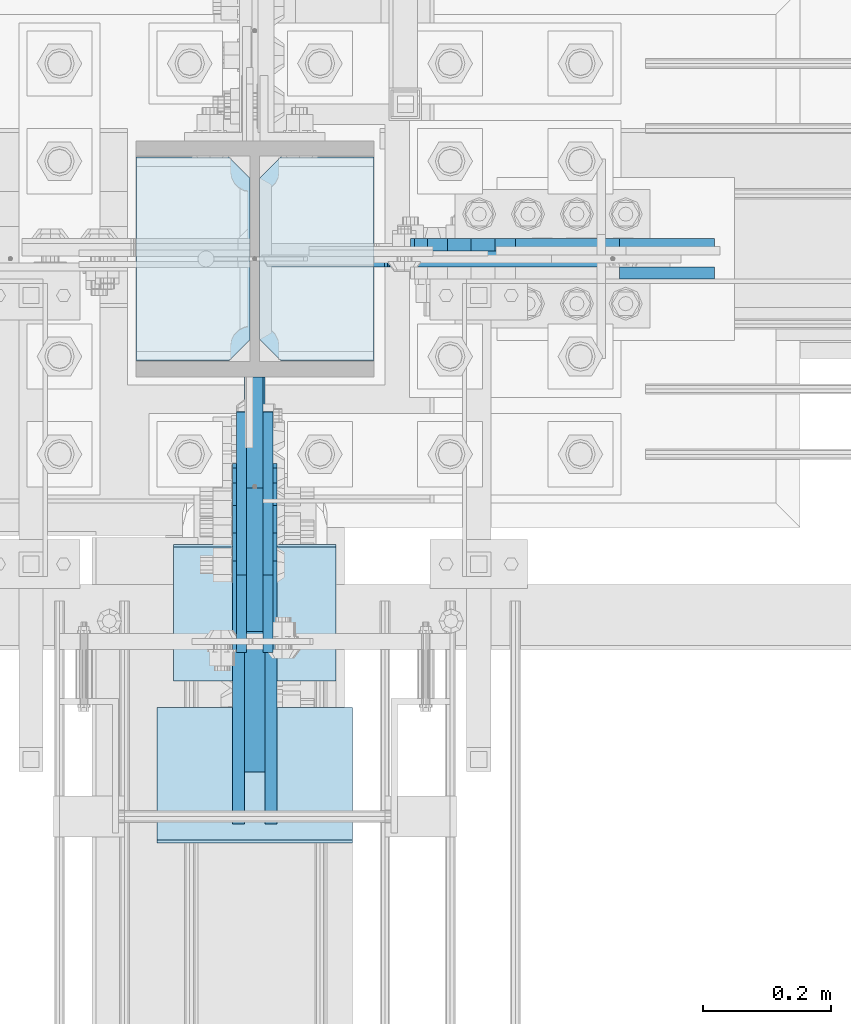
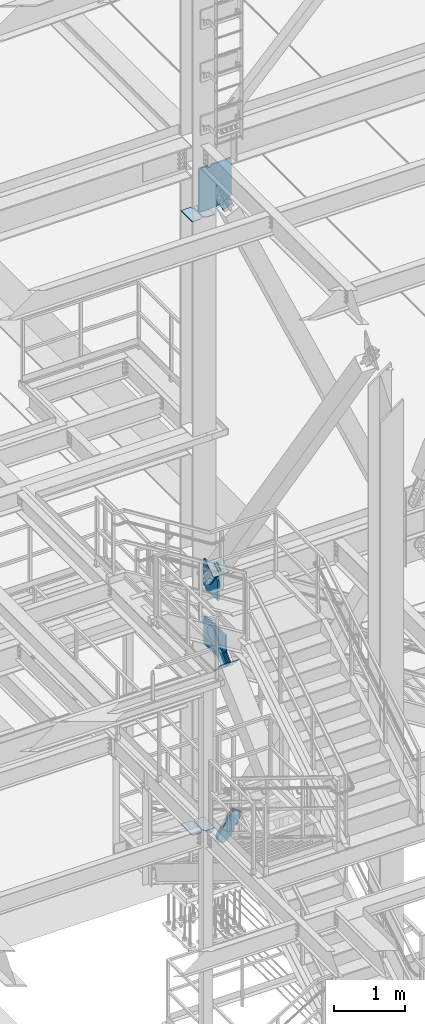
# One storey, part 3150 of 3843: 16 plates, 10 elements without a shape of their own.
"""IFC2X3 building model written with IfcOpenShell, lengths in millimetres."""

import ifcopenshell
import ifcopenshell.guid

model = None  # the IFC model being written
_history = None  # IfcOwnerHistory: only IFC2X3 demands one
_inside = {}  # id of a spatial element -> (the spatial element, [elements in it])
_under = {}  # id of a project, library or spatial element -> (it, [spatial elements below it])
_declared = {}  # id of a project -> (the project, [libraries it declares])
_typed = {}  # id of a type object -> (the type object, [elements of that type])
_made_of = {}  # id of a material, layer set ... -> (it, [elements and type objects made of it])


def new_model(schema):
    """Start an empty IFC model of exactly this schema.

    Asked for "IFC4X3", IfcOpenShell would pick the latest addendum, in which some entities
    have other attributes; the version numbers below select the first issue.
    IFC2X3 requires an IfcOwnerHistory on every rooted entity: one is made here for all.
    """
    global model, _history
    if schema == "IFC4X3":
        model = ifcopenshell.file(schema_version=(4, 3, 0, 0))
    else:
        model = ifcopenshell.file(schema=schema)
    _inside.clear()
    _under.clear()
    _declared.clear()
    _typed.clear()
    _made_of.clear()
    _history = None
    if model.schema == "IFC2X3":
        org = make("IfcOrganization", Name="unknown")
        user = make(
            "IfcPersonAndOrganization",
            ThePerson=make("IfcPerson", FamilyName="unknown"),
            TheOrganization=org,
        )
        app = make(
            "IfcApplication",
            ApplicationDeveloper=org,
            Version="unknown",
            ApplicationFullName="unknown",
            ApplicationIdentifier="unknown",
        )
        _history = make(
            "IfcOwnerHistory",
            OwningUser=user,
            OwningApplication=app,
            ChangeAction="ADDED",
            CreationDate=0,
        )
    return model


def make(cls, **values):
    """One entity of the class cls with the attributes given. An attribute that is None is left unset."""
    return model.create_entity(
        cls, **{name: value for name, value in values.items() if value is not None}
    )


def rooted(cls, **values):
    """An entity with a GlobalId (a new one), such as an element, a storey or a relation."""
    return make(cls, GlobalId=ifcopenshell.guid.new(), OwnerHistory=_history, **values)


def si_unit(unit_type, name, prefix=None):
    """IfcSIUnit, for example si_unit("LENGTHUNIT", "METRE", prefix="MILLI")."""
    return make("IfcSIUnit", UnitType=unit_type, Prefix=prefix, Name=name)


def assignment(units):
    """IfcUnitAssignment: the units of a project."""
    return None if units is None else make("IfcUnitAssignment", Units=units)


def point(xyz):
    """IfcCartesianPoint."""
    return None if xyz is None else make("IfcCartesianPoint", Coordinates=xyz)


def direction(xyz):
    """IfcDirection."""
    return None if xyz is None else make("IfcDirection", DirectionRatios=xyz)


def frame(location, z_axis=None, x_axis=None):
    """IfcAxis2Placement3D, a coordinate frame: its origin and axes. An axis left out is left unset."""
    return make(
        "IfcAxis2Placement3D",
        Location=point(location),
        Axis=direction(z_axis),
        RefDirection=direction(x_axis),
    )


def origin_with_axes():
    """The frame at (0, 0, 0) with the z axis (0, 0, 1) and the x axis (1, 0, 0) written out."""
    return frame((0.0, 0.0, 0.0), z_axis=(0.0, 0.0, 1.0), x_axis=(1.0, 0.0, 0.0))


def place(relative_to, where):
    """IfcLocalPlacement: puts the frame where relative to a parent placement (None: the world)."""
    return make(
        "IfcLocalPlacement", PlacementRelTo=relative_to, RelativePlacement=where
    )


def context(
    kind, dimensions, precision=None, world=None, true_north=None, identifier=None
):
    """IfcGeometricRepresentationContext, for example the 3D "Model" context."""
    return make(
        "IfcGeometricRepresentationContext",
        ContextIdentifier=identifier,
        ContextType=kind,
        CoordinateSpaceDimension=dimensions,
        Precision=precision,
        WorldCoordinateSystem=world,
        TrueNorth=true_north,
    )


def subcontext(parent, identifier, kind, view, scale=None):
    """IfcGeometricRepresentationSubContext, for example "Body" below "Model"."""
    return make(
        "IfcGeometricRepresentationSubContext",
        ContextIdentifier=identifier,
        ContextType=kind,
        ParentContext=parent,
        TargetScale=scale,
        TargetView=view,
    )


def project(units=None, contexts=None):
    """IfcProject with its units and contexts."""
    return rooted(
        "IfcProject",
        Name="project",
        RepresentationContexts=contexts,
        UnitsInContext=assignment(units),
    )


def spatial(cls, under=None, at=None, **own):
    """A site, building, storey or space (cls), placed at a placement, below another one or the project."""
    s = rooted(cls, ObjectPlacement=at, **own)
    if under is not None:
        _under.setdefault(under.id(), (under, []))[1].append(s)
    return s


def faces_of(points, faces, orient=None, outer=None):
    """IfcFace entities. A face is a list of loops; a loop is a list of indices into points, from 0.

    orient and outer hold one flag for each loop. By default every Orientation is true, the
    first loop of a face is its IfcFaceOuterBound and the others are IfcFaceBound.
    """
    made = []
    for i, loops in enumerate(faces):
        bounds = []
        for j, loop in enumerate(loops):
            is_outer = j == 0 if outer is None else outer[i][j]
            bounds.append(
                make(
                    "IfcFaceOuterBound" if is_outer else "IfcFaceBound",
                    Bound=make("IfcPolyLoop", Polygon=[points[k] for k in loop]),
                    Orientation=True if orient is None else orient[i][j],
                )
            )
        made.append(make("IfcFace", Bounds=bounds))
    return made


def faceted_brep(points, faces, orient=None, outer=None, voids=None):
    """IfcFacetedBrep: a solid bounded by flat faces; with voids (closed shells), ...WithVoids."""
    shared = [point(p) for p in points]
    hull = make("IfcClosedShell", CfsFaces=faces_of(shared, faces, orient, outer))
    if voids is None:
        return make("IfcFacetedBrep", Outer=hull)
    return make(
        "IfcFacetedBrepWithVoids",
        Outer=hull,
        Voids=[
            make(cls, CfsFaces=faces_of(shared, fs, o, b)) for cls, fs, o, b in voids
        ],
    )


def shape(context_of_items, identifier, shape_type, items):
    """IfcShapeRepresentation: the items that make up one representation, for example the "Body"."""
    return make(
        "IfcShapeRepresentation",
        ContextOfItems=context_of_items,
        RepresentationIdentifier=identifier,
        RepresentationType=shape_type,
        Items=items,
    )


def material(Name=None, Category=None):
    """IfcMaterial."""
    return make("IfcMaterial", Name=Name, Category=Category)


def made_of(thing, what):
    """Note that an element or type object is made of a material, layer set ...; save() writes the relation."""
    if what is not None:
        _made_of.setdefault(what.id(), (what, []))[1].append(thing)
    return thing


def type_object(cls, material=None, **own):
    """A type object (cls), such as IfcWallType, which elements share."""
    return made_of(rooted(cls, **own), material)


def element(
    cls,
    number,
    at=None,
    inside=None,
    cuts=None,
    type_object=None,
    material=None,
    context=None,
    identifier="Body",
    shape_type=None,
    held_by="IfcProductDefinitionShape",
    body=None,
    shapes=None,
    **own,
):
    """One element of the class cls, such as IfcWall. Its Tag is "e" and its number.

    at: its placement. inside: the storey or other place that contains it. cuts: it is an
    opening in that element (IfcRelVoidsElement). A single representation is given by context,
    identifier, shape_type and body (its items); several are given by shapes. held_by: the class
    of the entity that holds the representations. save() writes the other relations.
    """
    e = rooted(cls, Tag="e%d" % number, ObjectPlacement=at, **own)
    if body is not None:
        shapes = [shape(context, identifier, shape_type, body)]
    if shapes is not None:
        e.Representation = make(held_by, Representations=shapes)
    if inside is not None:
        _inside.setdefault(inside.id(), (inside, []))[1].append(e)
    if cuts is not None:
        rooted(
            "IfcRelVoidsElement", RelatingBuildingElement=cuts, RelatedOpeningElement=e
        )
    if type_object is not None:
        _typed.setdefault(type_object.id(), (type_object, []))[1].append(e)
    return made_of(e, material)


def aggregate(whole, parts):
    """IfcRelAggregates: a whole, such as a stair, and the parts it consists of."""
    return rooted("IfcRelAggregates", RelatingObject=whole, RelatedObjects=parts)


def save(model, path):
    """Write the relations noted so far, then the file.

    IfcRelAggregates (storeys below a building ...), IfcRelContainedInSpatialStructure (elements
    in a storey), IfcRelDefinesByType, IfcRelAssociatesMaterial and IfcRelDeclares: one each for
    every whole, place, type object, material and project.
    """
    for whole, parts in _under.values():
        aggregate(whole, parts)
    for where, things in _inside.values():
        rooted(
            "IfcRelContainedInSpatialStructure",
            RelatedElements=things,
            RelatingStructure=where,
        )
    for kind, things in _typed.values():
        rooted("IfcRelDefinesByType", RelatedObjects=things, RelatingType=kind)
    for what, things in _made_of.values():
        rooted("IfcRelAssociatesMaterial", RelatedObjects=things, RelatingMaterial=what)
    for by, libraries in _declared.values():
        rooted("IfcRelDeclares", RelatingContext=by, RelatedDefinitions=libraries)
    model.write(path)


model = new_model("IFC2X3")

# Units and contexts
model_context = context("Model", 3, precision=1e-05, world=origin_with_axes())
body_context = subcontext(model_context, "Body", "Model", "MODEL_VIEW")
ifc_project = project(units=[si_unit("LENGTHUNIT", "METRE", prefix="MILLI"), si_unit("AREAUNIT", "SQUARE_METRE"), si_unit("VOLUMEUNIT", "CUBIC_METRE"), si_unit("MASSUNIT", "GRAM", prefix="KILO"), si_unit("TIMEUNIT", "SECOND"), si_unit("PLANEANGLEUNIT", "RADIAN"), si_unit("SOLIDANGLEUNIT", "STERADIAN"), si_unit("THERMODYNAMICTEMPERATUREUNIT", "DEGREE_CELSIUS"), si_unit("LUMINOUSINTENSITYUNIT", "LUMEN")], contexts=[model_context])

# Site, building, storey
site_placement = place(None, origin_with_axes())
site = spatial("IfcSite", under=ifc_project, at=site_placement, CompositionType="ELEMENT")
building_placement = place(site_placement, origin_with_axes())
building = spatial("IfcBuilding", under=site, at=building_placement, Name="Undefined", CompositionType="ELEMENT")
storey_placement = place(building_placement, origin_with_axes())
storey = spatial("IfcBuildingStorey", under=building, at=storey_placement, Name="Undefined", CompositionType="ELEMENT", Elevation=0.0)

# Assembly, plates
assembly_1_placement = place(storey_placement, origin_with_axes())
assembly_1 = element("IfcElementAssembly", 1, at=assembly_1_placement, inside=storey, Name="COLUMN", AssemblyPlace="NOTDEFINED", PredefinedType="RIGID_FRAME")
ifc_material_1 = material(Name="STEEL/A572-50")
plate_type_1 = type_object("IfcPlateType", PredefinedType="NOTDEFINED")
plate_1_placement = place(assembly_1_placement, frame((55937.94375, 25457.15, 30568.9380949005), z_axis=(1.0, 0.0, 0.0), x_axis=(0.0, 1.0, 0.0)))
plate_1 = element("IfcPlate", 2, at=plate_1_placement, type_object=plate_type_1, material=ifc_material_1, Name="CB_COL", context=body_context, shape_type="Brep", body=[
    faceted_brep([(0.0, -6.34999999999854, 33.3375015258789), (0.0, -6.34999999999854, 178.59375), (0.0, 6.34999999999854, 178.59375), (0.0, 6.34999999999854, 33.3375015258789), (317.499999999985, -6.34999999999854, 178.59375), (317.499999999985, 6.34999999999854, 178.59375), (317.499999999985, -6.34999999999854, 33.3375015258789), (317.499999999985, 6.34999999999854, 33.3375015258789), (284.162498474107, -6.34999999999854, 0.0), (284.162498474107, 6.34999999999854, 0.0), (33.3375015258789, -6.34999999999854, 0.0), (33.3375015258789, 6.34999999999854, 0.0)], [[[0, 1, 2, 3]], [[1, 4, 5, 2]], [[4, 6, 7, 5]], [[6, 8, 9, 7]], [[8, 10, 11, 9]], [[10, 0, 3, 11]], [[5, 7, 9, 11, 3, 2]], [[10, 8, 6, 4, 1, 0]]]),
])
plate_2_placement = place(assembly_1_placement, frame((55923.65625, 25457.15, 30568.9380949005), z_axis=(-1.0, 0.0, 0.0), x_axis=(0.0, 1.0, 0.0)))
plate_2 = element("IfcPlate", 3, at=plate_2_placement, type_object=plate_type_1, material=ifc_material_1, Name="CB_COL", context=body_context, shape_type="Brep", body=[
    faceted_brep([(0.0, -6.34999999999854, 33.3375015258789), (0.0, -6.34999999999854, 178.59375), (0.0, 6.34999999999854, 178.59375), (0.0, 6.34999999999854, 33.3375015258789), (317.499999999985, -6.34999999999854, 178.59375), (317.499999999985, 6.34999999999854, 178.59375), (317.499999999985, -6.34999999999854, 33.3375015258789), (317.499999999985, 6.34999999999854, 33.3375015258789), (284.162498474107, -6.34999999999854, 0.0), (284.162498474107, 6.34999999999854, 0.0), (33.3375015258789, -6.34999999999854, 0.0), (33.3375015258789, 6.34999999999854, 0.0)], [[[0, 1, 2, 3]], [[1, 4, 5, 2]], [[4, 6, 7, 5]], [[6, 8, 9, 7]], [[8, 10, 11, 9]], [[10, 0, 3, 11]], [[5, 7, 9, 11, 3, 2]], [[10, 8, 6, 4, 1, 0]]]),
])
plate_3_placement = place(assembly_1_placement, frame((55937.94375, 25457.15, 41164.1593790225), z_axis=(1.0, 0.0, 0.0), x_axis=(0.0, 1.0, 0.0)))
plate_3 = element("IfcPlate", 4, at=plate_3_placement, type_object=plate_type_1, material=ifc_material_1, Name="CB_COL", context=body_context, shape_type="Brep", body=[
    faceted_brep([(0.0, -6.34999999999854, 33.3375015258789), (0.0, -6.34999999999854, 178.59375), (0.0, 6.34999999999854, 178.59375), (0.0, 6.34999999999854, 33.3375015258789), (317.499999999985, -6.34999999999854, 178.59375), (317.499999999985, 6.34999999999854, 178.59375), (317.499999999985, -6.34999999999854, 33.3375015258789), (317.499999999985, 6.34999999999854, 33.3375015258789), (284.162498474107, -6.34999999999854, 0.0), (284.162498474107, 6.34999999999854, 0.0), (33.3375015258789, -6.34999999999854, 0.0), (33.3375015258789, 6.34999999999854, 0.0)], [[[0, 1, 2, 3]], [[1, 4, 5, 2]], [[4, 6, 7, 5]], [[6, 8, 9, 7]], [[8, 10, 11, 9]], [[10, 0, 3, 11]], [[5, 7, 9, 11, 3, 2]], [[10, 8, 6, 4, 1, 0]]]),
])
plate_4_placement = place(assembly_1_placement, frame((55923.65625, 25457.15, 41164.1593790225), z_axis=(-1.0, 0.0, 0.0), x_axis=(0.0, 1.0, 0.0)))
plate_4 = element("IfcPlate", 5, at=plate_4_placement, type_object=plate_type_1, material=ifc_material_1, Name="CB_COL", context=body_context, shape_type="Brep", body=[
    faceted_brep([(0.0, -6.34999999999854, 33.3375015258789), (0.0, -6.34999999999854, 178.59375), (0.0, 6.34999999999854, 178.59375), (0.0, 6.34999999999854, 33.3375015258789), (317.499999999985, -6.34999999999854, 178.59375), (317.499999999985, 6.34999999999854, 178.59375), (317.499999999985, -6.34999999999854, 33.3375015258789), (317.499999999985, 6.34999999999854, 33.3375015258789), (284.162498474107, -6.34999999999854, 0.0), (284.162498474107, 6.34999999999854, 0.0), (33.3375015258789, -6.34999999999854, 0.0), (33.3375015258789, 6.34999999999854, 0.0)], [[[0, 1, 2, 3]], [[1, 4, 5, 2]], [[4, 6, 7, 5]], [[6, 8, 9, 7]], [[8, 10, 11, 9]], [[10, 0, 3, 11]], [[5, 7, 9, 11, 3, 2]], [[10, 8, 6, 4, 1, 0]]]),
])
plate_type_2 = type_object("IfcPlateType", PredefinedType="NOTDEFINED")
plate_5_placement = place(assembly_1_placement, frame((56470.2907172515, 25615.9, 42468.8), z_axis=(0.0, 0.0, -1.0), x_axis=(-1.0, 0.0, 0.0)))
plate_5 = element("IfcPlate", 6, at=plate_5_placement, type_object=plate_type_2, material=ifc_material_1, Name="CB", context=body_context, shape_type="Brep", body=[
    faceted_brep([(329.024020965706, -12.7000000000007, 542.925000000003), (329.024020965706, 12.7000000000007, 542.925000000003), (329.024020965706, 12.7000000000007, 568.325000190736), (329.024020965706, -12.7000000000007, 568.325000190736), (329.990750888297, 12.7000000000007, 573.185079708783), (329.990750888297, -12.7000000000007, 573.185079708783), (332.743764788771, 12.7000000000007, 577.305256176936), (332.743764788771, -12.7000000000007, 577.305256176936), (336.863941256925, 12.7000000000007, 580.05827007741), (336.863941256925, -12.7000000000007, 580.05827007741), (341.724020774971, 12.7000000000007, 581.025000000001), (341.724020774971, -12.7000000000007, 581.025000000001), (366.453217442249, 12.7000000000007, 581.025000000001), (366.453217442249, -12.7000000000007, 581.025000000001), (371.313296960296, 12.7000000000007, 580.05827007741), (371.313296960296, -12.7000000000007, 580.05827007741), (375.433473428449, 12.7000000000007, 577.305256176936), (375.433473428449, -12.7000000000007, 577.305256176936), (378.186487328923, 12.7000000000007, 573.185079708783), (378.186487328923, -12.7000000000007, 573.185079708783), (379.153217251514, -12.7000000000007, 568.325000190736), (379.153217251514, 12.7000000000007, 568.325000190736), (379.153217251514, 12.7000000000007, 542.925000000003), (379.153217251514, -12.7000000000007, 542.925000000003), (0.0, -12.7000000000007, 1188.66468498625), (0.0, 12.7000000000007, 1188.66468498625), (0.0, 12.7000000000007, 542.925000000003), (0.0, -12.7000000000007, 542.925000000003), (248.987096405486, -12.7000000000007, 1298.2906209775), (248.987096405486, 12.7000000000007, 1298.2906209775), (514.090717632986, -12.7000000000007, 1298.2906209775), (514.090717632986, 12.7000000000007, 1298.2906209775), (532.346967251513, -12.7000000000007, 1280.03437135898), (532.346967251513, 12.7000000000007, 1280.03437135898), (532.346967251513, 12.7000000000007, 561.975000000006), (532.346967251513, -12.7000000000007, 561.975000000006), (513.296967251517, -12.7000000000007, 542.925000000003), (513.296967251517, 12.7000000000007, 542.925000000003)], [[[0, 1, 2, 3]], [[3, 2, 4, 5]], [[5, 4, 6, 7]], [[7, 6, 8, 9]], [[9, 8, 10, 11]], [[11, 10, 12, 13]], [[13, 12, 14, 15]], [[15, 14, 16, 17]], [[17, 16, 18, 19]], [[20, 21, 22, 23]], [[19, 18, 21, 20]], [[24, 25, 26, 27]], [[24, 28, 29, 25]], [[28, 30, 31, 29]], [[31, 30, 32, 33]], [[34, 33, 32, 35]], [[34, 35, 36, 37]], [[37, 36, 23, 22]], [[16, 14, 12, 10, 8, 6, 4, 2, 1, 26, 25, 29, 31, 33, 34, 37, 22, 21, 18]], [[27, 26, 1, 0]], [[36, 35, 32, 30, 28, 24, 27, 0, 3, 5, 7, 9, 11, 13, 15, 17, 19, 20, 23]]]),
])

# Assembly, plate
assembly_2_placement = place(storey_placement, origin_with_axes())
assembly_2 = element("IfcElementAssembly", 7, at=assembly_2_placement, inside=storey, AssemblyPlace="NOTDEFINED", PredefinedType="RIGID_FRAME")
ifc_material_2 = material(Name="STEEL/A36")
plate_type_3 = type_object("IfcPlateType", PredefinedType="NOTDEFINED")
plate_6_placement = place(assembly_2_placement, frame((56608.8176355638, 25638.125, 30512.4906977269), z_axis=(-0.825520173434153, 0.0, 0.564372610296821), x_axis=(0.564372610296811, 0.0, 0.825520173434159)))
plate_6 = element("IfcPlate", 8, at=plate_6_placement, type_object=plate_type_3, material=ifc_material_2, context=body_context, shape_type="Brep", body=[
    faceted_brep([(0.0, -9.52500000000146, 0.0), (-101.59999999866, -9.52499999999418, -7.01164927375794), (-101.59999999866, 9.52499999999418, -7.01164927375794), (0.0, 9.52500000000146, 0.0), (-364.729297655074, -9.52499999999418, -7.01164927444188), (-364.729297655074, 9.52499999999418, -7.01164927444188), (-401.787405121293, -9.52499999999418, 0.359666612348519), (-401.787405121293, 9.52499999999418, 0.359666612348519), (-433.203751657995, -9.52499999999418, 21.3513982502482), (-433.203751657995, 9.52499999999418, 21.3513982502482), (-454.195483294687, -9.52499999999418, 52.7677447877504), (-454.195483294687, 9.52499999999418, 52.7677447877504), (-461.566799180051, -9.52499999999418, 89.8258492000314), (-461.566799180051, 9.52499999999418, 89.8258492000314), (-454.195483292249, -9.52499999999418, 126.883956664562), (-454.195483292249, 9.52499999999418, 126.883956664562), (-433.203751654662, -9.52499999999418, 158.300303199998), (-433.203751654662, 9.52499999999418, 158.300303199998), (-401.787405118426, -9.52499999999418, 179.292034836384), (-401.787405118426, 9.52499999999418, 179.292034836384), (-364.729299177612, -9.52499999999418, 186.663350722738), (-364.729299177612, 9.52499999999418, 186.663350722738), (-101.5999999907, -9.52499999999418, 186.663350723451), (-101.5999999907, 9.52499999999418, 186.663350723451), (7.37782102078199e-09, -9.52499999999418, 179.651701450231), (7.37782102078199e-09, 9.52499999999418, 179.651701450231), (69.8500000062704, -9.52499999999418, 179.651701450392), (69.8500000062704, 9.52499999999418, 179.651701450392), (69.8499999979995, -9.52499999999418, -4.00177668780088e-10), (69.8499999979995, 9.52499999999418, -4.00177668780088e-10)], [[[0, 1, 2, 3]], [[1, 4, 5, 2]], [[4, 6, 7, 5]], [[6, 8, 9, 7]], [[8, 10, 11, 9]], [[10, 12, 13, 11]], [[12, 14, 15, 13]], [[14, 16, 17, 15]], [[16, 18, 19, 17]], [[18, 20, 21, 19]], [[20, 22, 23, 21]], [[22, 24, 25, 23]], [[24, 26, 27, 25]], [[26, 28, 29, 27]], [[28, 0, 3, 29]], [[5, 7, 9, 11, 13, 15, 17, 19, 21, 23, 25, 27, 29, 3, 2]], [[28, 26, 24, 22, 20, 18, 16, 14, 12, 10, 8, 6, 4, 1, 0]]]),
])
aggregate(assembly_2, [plate_6])

assembly_3_placement = place(storey_placement, origin_with_axes())
assembly_3 = element("IfcElementAssembly", 9, at=assembly_3_placement, inside=storey, AssemblyPlace="NOTDEFINED", PredefinedType="RIGID_FRAME")
plate_7_placement = place(assembly_3_placement, frame((56608.8176355638, 25593.675, 30512.4906977269), z_axis=(-0.825520173434153, 0.0, 0.564372610296821), x_axis=(0.564372610296811, 0.0, 0.825520173434159)))
plate_7 = element("IfcPlate", 10, at=plate_7_placement, type_object=plate_type_3, material=ifc_material_2, context=body_context, shape_type="Brep", body=[
    faceted_brep([(0.0, -9.52500000000146, 0.0), (-101.59999999866, -9.52499999999418, -7.01164927375794), (-101.59999999866, 9.52499999999418, -7.01164927375794), (0.0, 9.52500000000146, 0.0), (-364.729297655074, -9.52499999999418, -7.01164927444188), (-364.729297655074, 9.52499999999418, -7.01164927444188), (-401.787405121293, -9.52499999999418, 0.359666612348519), (-401.787405121293, 9.52499999999418, 0.359666612348519), (-433.203751657995, -9.52499999999418, 21.3513982502482), (-433.203751657995, 9.52499999999418, 21.3513982502482), (-454.195483294687, -9.52499999999418, 52.7677447877504), (-454.195483294687, 9.52499999999418, 52.7677447877504), (-461.566799180051, -9.52499999999418, 89.8258492000314), (-461.566799180051, 9.52499999999418, 89.8258492000314), (-454.195483292249, -9.52499999999418, 126.883956664562), (-454.195483292249, 9.52499999999418, 126.883956664562), (-433.203751654662, -9.52499999999418, 158.300303199998), (-433.203751654662, 9.52499999999418, 158.300303199998), (-401.787405118426, -9.52499999999418, 179.292034836384), (-401.787405118426, 9.52499999999418, 179.292034836384), (-364.729299177612, -9.52499999999418, 186.663350722738), (-364.729299177612, 9.52499999999418, 186.663350722738), (-101.5999999907, -9.52499999999418, 186.663350723451), (-101.5999999907, 9.52499999999418, 186.663350723451), (7.37782102078199e-09, -9.52499999999418, 179.651701450231), (7.37782102078199e-09, 9.52499999999418, 179.651701450231), (69.8500000062704, -9.52499999999418, 179.651701450392), (69.8500000062704, 9.52499999999418, 179.651701450392), (69.8499999979995, -9.52499999999418, -4.00177668780088e-10), (69.8499999979995, 9.52499999999418, -4.00177668780088e-10)], [[[0, 1, 2, 3]], [[1, 4, 5, 2]], [[4, 6, 7, 5]], [[6, 8, 9, 7]], [[8, 10, 11, 9]], [[10, 12, 13, 11]], [[12, 14, 15, 13]], [[14, 16, 17, 15]], [[16, 18, 19, 17]], [[18, 20, 21, 19]], [[20, 22, 23, 21]], [[22, 24, 25, 23]], [[24, 26, 27, 25]], [[26, 28, 29, 27]], [[28, 0, 3, 29]], [[5, 7, 9, 11, 13, 15, 17, 19, 21, 23, 25, 27, 29, 3, 2]], [[28, 26, 24, 22, 20, 18, 16, 14, 12, 10, 8, 6, 4, 1, 0]]]),
])
aggregate(assembly_3, [plate_7])

assembly_4_placement = place(storey_placement, origin_with_axes())
assembly_4 = element("IfcElementAssembly", 11, at=assembly_4_placement, inside=storey, AssemblyPlace="NOTDEFINED", PredefinedType="RIGID_FRAME")
plate_8_placement = place(assembly_4_placement, frame((56471.840024458, 25638.125, 41169.8056493382), z_axis=(-0.915217968956094, 0.0, -0.402959140980674), x_axis=(0.402959140980677, 0.0, -0.915217968956092)))
plate_8 = element("IfcPlate", 12, at=plate_8_placement, type_object=plate_type_3, material=ifc_material_2, context=body_context, shape_type="Brep", body=[
    faceted_brep([(0.0, -9.52500000000146, 0.0), (-101.599999999169, -9.52499999999418, -17.6403935107228), (-101.599999999169, 9.52499999999418, -17.6403935107228), (0.0, 9.52500000000146, 0.0), (-320.279297659972, -9.52499999999418, -17.640393512258), (-320.279297659972, 9.52499999999418, -17.640393512258), (-357.3374051259, -9.52499999999418, -10.2690776257878), (-357.3374051259, 9.52499999999418, -10.2690776257878), (-388.753751662653, -9.52499999999418, 10.7226540115298), (-388.753751662653, 9.52499999999418, 10.7226540115298), (-409.745483299826, -9.52499999999418, 42.1390005483918), (-409.745483299826, 9.52499999999418, 42.1390005483918), (-417.116799186137, -9.52499999999418, 79.1971049608474), (-417.116799186137, 9.52499999999418, 79.1971049608474), (-409.745483299252, -9.52499999999418, 116.255212426157), (-409.745483299252, 9.52499999999418, 116.255212426157), (-388.75375166202, -9.52499999999418, 147.671558962465), (-388.75375166202, 9.52499999999418, 147.671558962465), (-357.33740512564, -9.52499999999418, 168.663290599579), (-357.33740512564, 9.52499999999418, 168.663290599579), (-320.279299186061, -9.52499999999418, 176.034606486319), (-320.279299186061, 9.52499999999418, 176.034606486319), (-101.599999997048, -9.52499999999418, 176.034606487883), (-101.599999997048, 9.52499999999418, 176.034606487883), (1.71894498635083e-09, -9.52499999999418, 158.39421297863), (1.71894498635083e-09, 9.52499999999418, 158.39421297863), (69.8500000010408, -9.52499999999418, 158.394212979103), (69.8500000010408, 9.52499999999418, 158.394212979103), (69.8499999979995, -9.52499999999418, -4.00177668780088e-10), (69.8499999979995, 9.52499999999418, -4.00177668780088e-10)], [[[0, 1, 2, 3]], [[1, 4, 5, 2]], [[4, 6, 7, 5]], [[6, 8, 9, 7]], [[8, 10, 11, 9]], [[10, 12, 13, 11]], [[12, 14, 15, 13]], [[14, 16, 17, 15]], [[16, 18, 19, 17]], [[18, 20, 21, 19]], [[20, 22, 23, 21]], [[22, 24, 25, 23]], [[24, 26, 27, 25]], [[26, 28, 29, 27]], [[28, 0, 3, 29]], [[5, 7, 9, 11, 13, 15, 17, 19, 21, 23, 25, 27, 29, 3, 2]], [[28, 26, 24, 22, 20, 18, 16, 14, 12, 10, 8, 6, 4, 1, 0]]]),
])
aggregate(assembly_4, [plate_8])

assembly_5_placement = place(storey_placement, origin_with_axes())
assembly_5 = element("IfcElementAssembly", 13, at=assembly_5_placement, inside=storey, Name="Plate", AssemblyPlace="NOTDEFINED", PredefinedType="RIGID_FRAME")
plate_type_4 = type_object("IfcPlateType", PredefinedType="NOTDEFINED")
plate_9_placement = place(assembly_5_placement, frame((55803.8, 24959.3614882636, 35306.3021519367), z_axis=(0.0, 0.822893061718405, 0.568196276805568), x_axis=(1.0, 0.0, 0.0)))
plate_9 = element("IfcPlate", 14, at=plate_9_placement, type_object=plate_type_4, material=ifc_material_2, Name="Plate", context=body_context, shape_type="Brep", body=[
    faceted_brep([(0.0, -3.17499999999927, 0.0), (0.0, -3.17499999965185, 254.000000005151), (0.0, 3.17500000035216, 254.000000005166), (0.0, 3.17499999999927, 0.0), (254.0, -3.17499999965185, 254.000000005151), (254.0, 3.17500000035216, 254.000000005166), (254.0, -3.17500000000291, 0.0), (254.0, 3.17499999999927, 1.45519152283669e-11)], [[[0, 1, 2, 3]], [[1, 4, 5, 2]], [[4, 6, 7, 5]], [[6, 0, 3, 7]], [[5, 7, 3, 2]], [[6, 4, 1, 0]]]),
])
aggregate(assembly_5, [plate_9])

# Plate
plate_type_5 = type_object("IfcPlateType", PredefinedType="NOTDEFINED")
plate_10_placement = place(assembly_1_placement, frame((55930.8, 25431.75, 34810.7), z_axis=(0.0, 0.0, 1.0), x_axis=(0.0, -1.0, 0.0)))
plate_10 = element("IfcPlate", 15, at=plate_10_placement, type_object=plate_type_5, material=ifc_material_1, Name="CB", context=body_context, shape_type="Brep", body=[
    faceted_brep([(0.0, -12.6999999999971, 38.0999999999913), (0.0, 12.6999999999971, 38.0999999999913), (38.1000001907341, 12.6999999999971, 38.0999999999913), (38.1000001907341, -12.6999999999971, 38.0999999999913), (42.9600797087805, 12.6999999999971, 37.1332700774001), (42.9600797087805, -12.6999999999971, 37.1332700774001), (47.0802561769342, 12.6999999999971, 34.3802561769262), (47.0802561769342, -12.6999999999971, 34.3802561769262), (49.8332700774117, 12.6999999999971, 30.2600797087725), (49.8332700774117, -12.6999999999971, 30.2600797087725), (50.7999999999993, -12.6999999999971, 25.4000001907261), (50.7999999999993, 12.6999999999971, 25.4000001907261), (50.7999999999993, 12.6999999999971, 0.0), (50.7999999999993, -12.6999999999971, 0.0), (0.0, -12.6999999999971, 497.843630037154), (172.985816354667, -12.6999999999971, 497.843630037154), (172.985816354667, 12.6999999999971, 497.843630037154), (0.0, 12.6999999999971, 497.843630037154), (396.949912147324, -12.6999999999971, 343.199519778442), (396.949912147324, 12.6999999999971, 343.199519778442), (396.94991214732, -12.6999999999971, 0.0), (396.94991214732, 12.6999999999971, 0.0)], [[[0, 1, 2, 3]], [[3, 2, 4, 5]], [[5, 4, 6, 7]], [[7, 6, 8, 9]], [[10, 11, 12, 13]], [[9, 8, 11, 10]], [[14, 15, 16, 17]], [[15, 18, 19, 16]], [[18, 20, 21, 19]], [[21, 20, 13, 12]], [[6, 4, 2, 1, 17, 16, 19, 21, 12, 11, 8]], [[14, 17, 1, 0]], [[20, 18, 15, 14, 0, 3, 5, 7, 9, 10, 13]]]),
])

plate_type_6 = type_object("IfcPlateType", PredefinedType="NOTDEFINED")
plate_11_placement = place(assembly_1_placement, frame((55930.8, 24815.079886149, 34347.15), z_axis=(0.0, 0.0, -1.0), x_axis=(0.0, 1.0, 0.0)))
plate_11 = element("IfcPlate", 16, at=plate_11_placement, type_object=plate_type_6, material=ifc_material_1, Name="CB", context=body_context, shape_type="Brep", body=[
    faceted_brep([(0.0, -15.875, 268.309860016423), (212.73387055911, -15.875, 498.82634878478), (212.73387055911, 15.875, 498.82634878478), (0.0, 15.875, 268.309860016423), (616.670113850978, -15.875, 498.82634878478), (616.670113850978, 15.875, 498.82634878478), (616.670113850978, -15.875, 38.0999999999985), (616.670113850978, 15.875, 38.0999999999985), (578.570113660244, -15.875, 38.0999999999985), (578.570113660244, 15.875, 38.0999999999985), (573.710034142197, -15.875, 37.1332700774074), (573.710034142197, 15.875, 37.1332700774074), (569.589857674044, -15.875, 34.3802561769335), (569.589857674044, 15.875, 34.3802561769335), (566.836843773566, -15.875, 30.2600797087798), (566.836843773566, 15.875, 30.2600797087798), (565.870113850979, -15.875, 25.4000001907334), (565.870113850979, 15.875, 25.4000001907334), (565.870113850979, -15.875, 3.17500000000291), (565.870113850979, 15.875, 3.17500000000291), (-3.29036669216467e-13, 15.8749992370605, 3.17499995231628), (0.0, -15.875, 3.17500000000291)], [[[0, 1, 2, 3]], [[1, 4, 5, 2]], [[5, 4, 6, 7]], [[6, 8, 9, 7]], [[10, 11, 9, 8]], [[12, 13, 11, 10]], [[14, 15, 13, 12]], [[16, 17, 15, 14]], [[17, 16, 18, 19]], [[3, 2, 5, 7, 9, 11, 13, 15, 17, 19, 20]], [[0, 3, 20, 21]], [[16, 14, 12, 10, 8, 6, 4, 1, 0, 21, 18]], [[20, 19, 18, 21]]]),
])

aggregate(assembly_1, [plate_10, plate_11, plate_1, plate_2, plate_3, plate_4, plate_5])

# Assembly, plate
assembly_6_placement = place(storey_placement, origin_with_axes())
assembly_6 = element("IfcElementAssembly", 17, at=assembly_6_placement, inside=storey, AssemblyPlace="NOTDEFINED", PredefinedType="RIGID_FRAME")
plate_type_7 = type_object("IfcPlateType", PredefinedType="NOTDEFINED")
plate_12_placement = place(assembly_6_placement, frame((55910.1625, 25122.508370998, 35422.8111563268), z_axis=(0.0, -0.822893061718405, -0.568196276805568), x_axis=(0.0, 0.568196276805568, -0.822893061718405)))
plate_12 = element("IfcPlate", 18, at=plate_12_placement, type_object=plate_type_7, material=ifc_material_2, context=body_context, shape_type="Brep", body=[
    faceted_brep([(0.0, -7.9375, 0.0), (-3.63797880709171e-12, -7.9375, 146.90484030301), (-3.63797880709171e-12, 7.9375, 146.90484030301), (0.0, 7.9375, 0.0), (69.8500000004642, -7.9375, 146.904840303017), (69.8500000004642, 7.9375, 146.904840303017), (171.450000001149, -7.9375, 168.702420152127), (171.450000001149, 7.9375, 168.702420152127), (390.771138855567, -7.9375, 168.702420152127), (390.771138855567, 7.9375, 168.702420152127), (427.221735788375, -7.9375, 161.451945623819), (427.221735788375, 7.9375, 161.451945623819), (458.123059763651, -7.9375, 140.804341060117), (458.123059763651, 7.9375, 140.804341060117), (478.770664327354, -7.9375, 109.903017084849), (478.770664327354, 7.9375, 109.903017084849), (486.021138855662, -7.9375, 73.4524201509412), (486.021138855662, 7.9375, 73.4524201509412), (478.770664327352, -7.9375, 37.0018232181392), (478.770664327352, 7.9375, 37.0018232181392), (458.123059763644, -7.9375, 6.10049924285704), (458.123059763644, 7.9375, 6.10049924285704), (427.221735788367, -7.9375, -14.5471053208385), (427.221735788367, 7.9375, -14.5471053208385), (390.771138855016, -7.9375, -21.7975798491461), (390.771138855016, 7.9375, -21.7975798491461), (171.45000000115, -7.9375, -21.7975798491389), (171.45000000115, 7.9375, -21.7975798491389), (69.850000000486, -7.9375, 2.91038304567337e-11), (69.850000000486, 7.9375, 2.91038304567337e-11)], [[[0, 1, 2, 3]], [[1, 4, 5, 2]], [[4, 6, 7, 5]], [[6, 8, 9, 7]], [[8, 10, 11, 9]], [[10, 12, 13, 11]], [[12, 14, 15, 13]], [[14, 16, 17, 15]], [[16, 18, 19, 17]], [[18, 20, 21, 19]], [[20, 22, 23, 21]], [[22, 24, 25, 23]], [[24, 26, 27, 25]], [[26, 28, 29, 27]], [[28, 0, 3, 29]], [[5, 7, 9, 11, 13, 15, 17, 19, 21, 23, 25, 27, 29, 3, 2]], [[28, 26, 24, 22, 20, 18, 16, 14, 12, 10, 8, 6, 4, 1, 0]]]),
])
aggregate(assembly_6, [plate_12])

assembly_7_placement = place(storey_placement, origin_with_axes())
assembly_7 = element("IfcElementAssembly", 19, at=assembly_7_placement, inside=storey, AssemblyPlace="NOTDEFINED", PredefinedType="RIGID_FRAME")
plate_13_placement = place(assembly_7_placement, frame((55951.4375, 25122.508370998, 35422.8111563268), z_axis=(0.0, -0.822893061718405, -0.568196276805568), x_axis=(0.0, 0.568196276805568, -0.822893061718405)))
plate_13 = element("IfcPlate", 20, at=plate_13_placement, type_object=plate_type_7, material=ifc_material_2, context=body_context, shape_type="Brep", body=[
    faceted_brep([(0.0, -7.9375, 0.0), (-3.63797880709171e-12, -7.9375, 146.90484030301), (-3.63797880709171e-12, 7.9375, 146.90484030301), (0.0, 7.9375, 0.0), (69.8500000004642, -7.9375, 146.904840303017), (69.8500000004642, 7.9375, 146.904840303017), (171.450000001149, -7.9375, 168.702420152127), (171.450000001149, 7.9375, 168.702420152127), (390.771138855567, -7.9375, 168.702420152127), (390.771138855567, 7.9375, 168.702420152127), (427.221735788375, -7.9375, 161.451945623819), (427.221735788375, 7.9375, 161.451945623819), (458.123059763651, -7.9375, 140.804341060117), (458.123059763651, 7.9375, 140.804341060117), (478.770664327354, -7.9375, 109.903017084849), (478.770664327354, 7.9375, 109.903017084849), (486.021138855662, -7.9375, 73.4524201509412), (486.021138855662, 7.9375, 73.4524201509412), (478.770664327352, -7.9375, 37.0018232181392), (478.770664327352, 7.9375, 37.0018232181392), (458.123059763644, -7.9375, 6.10049924285704), (458.123059763644, 7.9375, 6.10049924285704), (427.221735788367, -7.9375, -14.5471053208385), (427.221735788367, 7.9375, -14.5471053208385), (390.771138855016, -7.9375, -21.7975798491461), (390.771138855016, 7.9375, -21.7975798491461), (171.45000000115, -7.9375, -21.7975798491389), (171.45000000115, 7.9375, -21.7975798491389), (69.850000000486, -7.9375, 2.91038304567337e-11), (69.850000000486, 7.9375, 2.91038304567337e-11)], [[[0, 1, 2, 3]], [[1, 4, 5, 2]], [[4, 6, 7, 5]], [[6, 8, 9, 7]], [[8, 10, 11, 9]], [[10, 12, 13, 11]], [[12, 14, 15, 13]], [[14, 16, 17, 15]], [[16, 18, 19, 17]], [[18, 20, 21, 19]], [[20, 22, 23, 21]], [[22, 24, 25, 23]], [[24, 26, 27, 25]], [[26, 28, 29, 27]], [[28, 0, 3, 29]], [[5, 7, 9, 11, 13, 15, 17, 19, 21, 23, 25, 27, 29, 3, 2]], [[28, 26, 24, 22, 20, 18, 16, 14, 12, 10, 8, 6, 4, 1, 0]]]),
])
aggregate(assembly_7, [plate_13])

assembly_8_placement = place(storey_placement, origin_with_axes())
assembly_8 = element("IfcElementAssembly", 21, at=assembly_8_placement, inside=storey, AssemblyPlace="NOTDEFINED", PredefinedType="RIGID_FRAME")
plate_type_8 = type_object("IfcPlateType", PredefinedType="NOTDEFINED")
plate_14_placement = place(assembly_8_placement, frame((55905.4, 24881.9022214559, 33753.6279342928), z_axis=(0.0, -0.678193033067635, 0.734883807073283), x_axis=(0.0, 0.734883807073284, 0.678193033067634)))
plate_14 = element("IfcPlate", 22, at=plate_14_placement, type_object=plate_type_8, material=ifc_material_2, context=body_context, shape_type="Brep", body=[
    faceted_brep([(0.0, -9.52500000000146, 0.0), (1.06956576928496e-09, -9.52500000000146, 217.493324627542), (1.06956576928496e-09, 9.52500000000146, 217.493324627542), (0.0, 9.52500000000146, 0.0), (69.8500000010463, -9.52500000000146, 217.493324627546), (69.8500000010463, 9.52500000000146, 217.493324627546), (171.450000001067, -9.52500000000146, 221.459162314371), (171.450000001067, 9.52500000000146, 221.459162314371), (511.01986434267, -9.52500000000146, 221.459162314385), (511.01986434267, 9.52500000000146, 221.459162314385), (554.153071297093, -9.52500000000146, 212.879434006368), (554.153071297093, 9.52500000000146, 212.879434006368), (590.719638496135, -9.52500000000146, 188.446434941775), (590.719638496135, 9.52500000000146, 188.446434941775), (615.152637560488, -9.52500000000146, 151.879867742514), (615.152637560488, 9.52500000000146, 151.879867742514), (623.732365868273, -9.52500000000146, 108.746663839108), (623.732365868273, 9.52500000000146, 108.746663839108), (615.152637560117, -9.52500000000146, 65.6134568847037), (615.152637560117, 9.52500000000146, 65.6134568847037), (590.719638495553, -9.52500000000146, 29.0468896856282), (590.719638495553, 9.52500000000146, 29.0468896856282), (554.153071296452, -9.52500000000146, 4.61389062117723), (554.153071296452, 9.52500000000146, 4.61389062117723), (511.019865867733, -9.52500000000146, -3.96583768680011), (511.019865867733, 9.52500000000146, -3.96583768680011), (171.449999999961, -9.52500000000146, -3.96583768681103), (171.449999999961, 9.52500000000146, -3.96583768681103), (69.8499999979995, -9.52499999999418, -4.00177668780088e-10), (69.8499999979995, 9.52499999999418, -4.00177668780088e-10)], [[[0, 1, 2, 3]], [[1, 4, 5, 2]], [[4, 6, 7, 5]], [[6, 8, 9, 7]], [[8, 10, 11, 9]], [[10, 12, 13, 11]], [[12, 14, 15, 13]], [[14, 16, 17, 15]], [[16, 18, 19, 17]], [[18, 20, 21, 19]], [[20, 22, 23, 21]], [[22, 24, 25, 23]], [[24, 26, 27, 25]], [[26, 28, 29, 27]], [[28, 0, 3, 29]], [[5, 7, 9, 11, 13, 15, 17, 19, 21, 23, 25, 27, 29, 3, 2]], [[28, 26, 24, 22, 20, 18, 16, 14, 12, 10, 8, 6, 4, 1, 0]]]),
])
aggregate(assembly_8, [plate_14])

assembly_9_placement = place(storey_placement, origin_with_axes())
assembly_9 = element("IfcElementAssembly", 23, at=assembly_9_placement, inside=storey, AssemblyPlace="NOTDEFINED", PredefinedType="RIGID_FRAME")
plate_15_placement = place(assembly_9_placement, frame((55956.2, 24881.9022214559, 33753.6279342928), z_axis=(0.0, -0.678193033067635, 0.734883807073283), x_axis=(0.0, 0.734883807073284, 0.678193033067634)))
plate_15 = element("IfcPlate", 24, at=plate_15_placement, type_object=plate_type_8, material=ifc_material_2, context=body_context, shape_type="Brep", body=[
    faceted_brep([(0.0, -9.52500000000146, 0.0), (1.06956576928496e-09, -9.52500000000146, 217.493324627542), (1.06956576928496e-09, 9.52500000000146, 217.493324627542), (0.0, 9.52500000000146, 0.0), (69.8500000010463, -9.52500000000146, 217.493324627546), (69.8500000010463, 9.52500000000146, 217.493324627546), (171.450000001067, -9.52500000000146, 221.459162314371), (171.450000001067, 9.52500000000146, 221.459162314371), (511.01986434267, -9.52500000000146, 221.459162314385), (511.01986434267, 9.52500000000146, 221.459162314385), (554.153071297093, -9.52500000000146, 212.879434006368), (554.153071297093, 9.52500000000146, 212.879434006368), (590.719638496135, -9.52500000000146, 188.446434941775), (590.719638496135, 9.52500000000146, 188.446434941775), (615.152637560488, -9.52500000000146, 151.879867742514), (615.152637560488, 9.52500000000146, 151.879867742514), (623.732365868273, -9.52500000000146, 108.746663839108), (623.732365868273, 9.52500000000146, 108.746663839108), (615.152637560117, -9.52500000000146, 65.6134568847037), (615.152637560117, 9.52500000000146, 65.6134568847037), (590.719638495553, -9.52500000000146, 29.0468896856282), (590.719638495553, 9.52500000000146, 29.0468896856282), (554.153071296452, -9.52500000000146, 4.61389062117723), (554.153071296452, 9.52500000000146, 4.61389062117723), (511.019865867733, -9.52500000000146, -3.96583768680011), (511.019865867733, 9.52500000000146, -3.96583768680011), (171.449999999961, -9.52500000000146, -3.96583768681103), (171.449999999961, 9.52500000000146, -3.96583768681103), (69.8499999979995, -9.52499999999418, -4.00177668780088e-10), (69.8499999979995, 9.52499999999418, -4.00177668780088e-10)], [[[0, 1, 2, 3]], [[1, 4, 5, 2]], [[4, 6, 7, 5]], [[6, 8, 9, 7]], [[8, 10, 11, 9]], [[10, 12, 13, 11]], [[12, 14, 15, 13]], [[14, 16, 17, 15]], [[16, 18, 19, 17]], [[18, 20, 21, 19]], [[20, 22, 23, 21]], [[22, 24, 25, 23]], [[24, 26, 27, 25]], [[26, 28, 29, 27]], [[28, 0, 3, 29]], [[5, 7, 9, 11, 13, 15, 17, 19, 21, 23, 25, 27, 29, 3, 2]], [[28, 26, 24, 22, 20, 18, 16, 14, 12, 10, 8, 6, 4, 1, 0]]]),
])
aggregate(assembly_9, [plate_15])

assembly_10_placement = place(storey_placement, origin_with_axes())
assembly_10 = element("IfcElementAssembly", 25, at=assembly_10_placement, inside=storey, Name="Plate", AssemblyPlace="NOTDEFINED", PredefinedType="RIGID_FRAME")
plate_type_9 = type_object("IfcPlateType", PredefinedType="NOTDEFINED")
plate_16_placement = place(assembly_10_placement, frame((56083.2, 24913.8408670332, 33723.7010661809), z_axis=(0.0, -0.678193033067635, 0.734883807073283), x_axis=(-1.0, 0.0, 0.0)))
plate_16 = element("IfcPlate", 26, at=plate_16_placement, type_object=plate_type_9, material=ifc_material_2, Name="Plate", context=body_context, shape_type="Brep", body=[
    faceted_brep([(0.0, -3.17499999999927, 0.0), (0.0, -3.17499999999927, 304.800000000003), (0.0, 3.17499999999927, 304.800000000003), (0.0, 3.17499999999927, 0.0), (304.800000000003, -3.17500000019936, 304.800000010334), (304.800000000003, 3.17499999980646, 304.800000010323), (304.800000000003, -3.17500000000291, 2.72848410531878e-12), (304.800000000003, 3.17499999999563, -4.54747350886464e-12)], [[[0, 1, 2, 3]], [[1, 4, 5, 2]], [[4, 6, 7, 5]], [[6, 0, 3, 7]], [[5, 7, 3, 2]], [[6, 4, 1, 0]]]),
])
aggregate(assembly_10, [plate_16])

save(model, "model.ifc")
